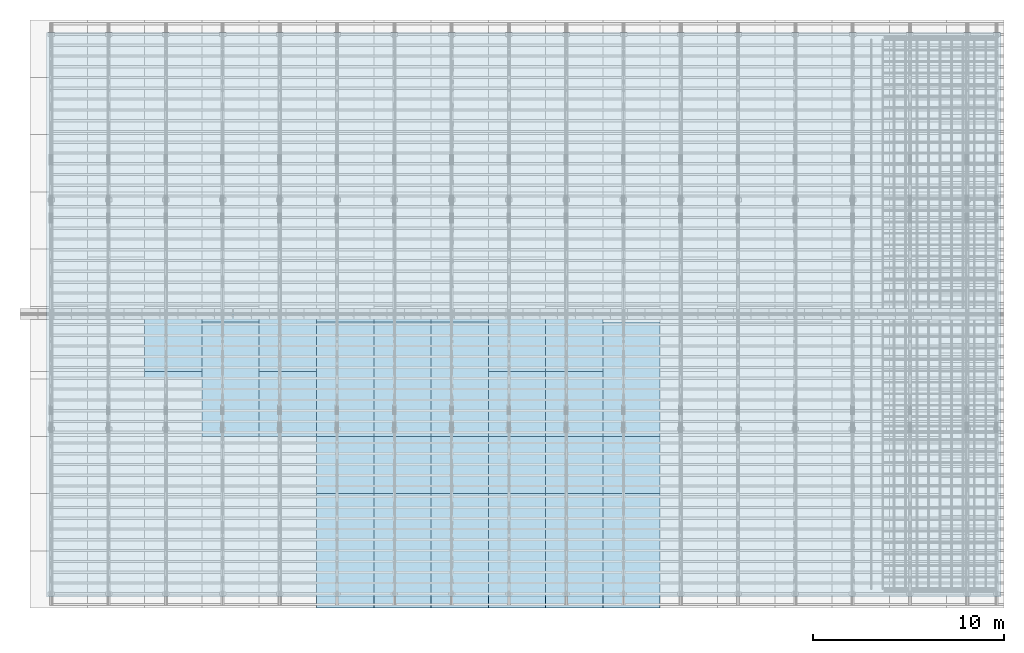
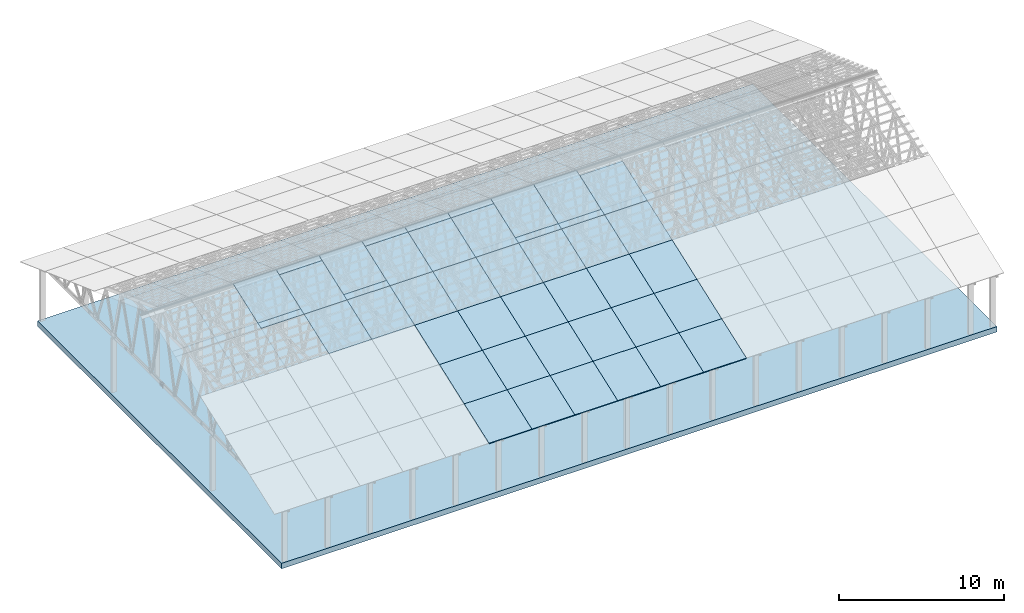
# One storey, part 6 of 189: 44 slabs, 43 elements without a shape of their own.
"""IFC2X3 building model written with IfcOpenShell, lengths in millimetres."""

from ifc_helpers import new_model, entity, si_unit, converted_unit, derived_unit, direction, frame, frame_2d, origin, place, context, subcontext, project, spatial, rectangle, extrude, material, layer, layer_set, type_object, element, aggregate, save


model = new_model("IFC2X3")

# Units and contexts
model_context = context("Model", 3, precision=0.01, world=origin(), true_north=direction((6.12303176911189e-17, 1.0)))
body_context = subcontext(model_context, "Body", "Model", "MODEL_VIEW")
ifc_project = project(units=[si_unit("LENGTHUNIT", "METRE", prefix="MILLI"), si_unit("AREAUNIT", "SQUARE_METRE"), si_unit("VOLUMEUNIT", "CUBIC_METRE"), converted_unit("PLANEANGLEUNIT", "DEGREE", entity("IfcRatioMeasure", 0.0174532925199433), si_unit("PLANEANGLEUNIT", "RADIAN"), dimensions=[0, 0, 0, 0, 0, 0, 0]), si_unit("MASSUNIT", "GRAM", prefix="KILO"), derived_unit("MASSDENSITYUNIT", [(si_unit("MASSUNIT", "GRAM", prefix="KILO"), 1), (si_unit("LENGTHUNIT", "METRE"), -3)]), si_unit("TIMEUNIT", "SECOND"), si_unit("FREQUENCYUNIT", "HERTZ"), si_unit("THERMODYNAMICTEMPERATUREUNIT", "DEGREE_CELSIUS"), derived_unit("THERMALTRANSMITTANCEUNIT", [(si_unit("MASSUNIT", "GRAM", prefix="KILO"), 1), (si_unit("THERMODYNAMICTEMPERATUREUNIT", "KELVIN"), -1), (si_unit("TIMEUNIT", "SECOND"), -3)]), derived_unit("VOLUMETRICFLOWRATEUNIT", [(si_unit("LENGTHUNIT", "METRE"), 3), (si_unit("TIMEUNIT", "SECOND"), -1)]), si_unit("ELECTRICCURRENTUNIT", "AMPERE"), si_unit("ELECTRICVOLTAGEUNIT", "VOLT"), si_unit("POWERUNIT", "WATT"), si_unit("FORCEUNIT", "NEWTON"), si_unit("ILLUMINANCEUNIT", "LUX"), si_unit("LUMINOUSFLUXUNIT", "LUMEN"), si_unit("LUMINOUSINTENSITYUNIT", "CANDELA"), derived_unit("USERDEFINED", [(si_unit("MASSUNIT", "GRAM", prefix="KILO"), -1), (si_unit("LENGTHUNIT", "METRE"), -2), (si_unit("TIMEUNIT", "SECOND"), 3), (si_unit("LUMINOUSFLUXUNIT", "LUMEN"), 1)]), derived_unit("LINEARVELOCITYUNIT", [(si_unit("LENGTHUNIT", "METRE"), 1), (si_unit("TIMEUNIT", "SECOND"), -1)]), si_unit("PRESSUREUNIT", "PASCAL"), derived_unit("USERDEFINED", [(si_unit("LENGTHUNIT", "METRE"), -2), (si_unit("MASSUNIT", "GRAM", prefix="KILO"), 1), (si_unit("TIMEUNIT", "SECOND"), -2)])], contexts=[model_context])

# Site, building, storey
site_placement = place(None, origin())
site = spatial("IfcSite", under=ifc_project, at=site_placement, CompositionType="ELEMENT")
building_placement = place(site_placement, origin())
building = spatial("IfcBuilding", under=site, at=building_placement, CompositionType="ELEMENT")
storey_placement = place(building_placement, origin())
storey = spatial("IfcBuildingStorey", under=building, at=storey_placement, Name="Default", CompositionType="ELEMENT", Elevation=0.0)

# Slab
ifc_material_1 = material(Name="IfcSurfaceStyle #136")
slab_type = type_object("IfcSlabType", Name="Floor 1", PredefinedType="FLOOR", material=ifc_material_1)
slab_1_placement = place(building_placement, origin())
element("IfcSlab", 1, at=slab_1_placement, inside=storey, type_object=slab_type, Name="Floor 1:Floor 1", ObjectType="Floor 1:Floor 1", PredefinedType="FLOOR", context=body_context, shape_type="SweptSolid", body=[
    extrude(rectangle(XDim=50000.0, YDim=29560.0, at=frame_2d((0.0, -2.72848410531878e-12), x_axis=(1.0, 0.0))), frame((25000.0, 14720.0, -4400.0), z_axis=(0.0, 0.0, 1.0), x_axis=(-1.0, 0.0, 0.0)), (0.0, 0.0, 1.0), 399.999999999997),
])

# Roof, slab
roof_1_placement = place(storey_placement, frame((29153.4200853156, -652.222549250773, 238.115215731819)))
roof_1 = element("IfcRoof", 2, at=roof_1_placement, inside=storey, ShapeType="NOTDEFINED")
ifc_material_2 = material()
ifc_layer = layer(ifc_material_2, 40.0)
ifc_layer_set = layer_set([ifc_layer])
slab_2_placement = place(roof_1_placement, origin())
slab_2 = element("IfcSlab", 3, at=slab_2_placement, material=ifc_layer_set, PredefinedType="ROOF", context=body_context, shape_type="SweptSolid", body=[
    extrude(rectangle(XDim=3192.53331742773, YDim=2999.99999999999, at=frame_2d((0.0, -3.41060513164848e-13), x_axis=(0.0, -1.0))), frame((1500.0, 1500.0, 545.955351399302), z_axis=(0.0, -0.342020143325668, 0.939692620785909), x_axis=(1.0, 0.0, 0.0)), (0.0, 0.342020143325668, 0.939692620785909), 42.5671108990364),
])
aggregate(roof_1, [slab_2])

roof_2_placement = place(storey_placement, frame((29153.4200853156, 2347.77745074922, 1330.02591853042)))
roof_2 = element("IfcRoof", 4, at=roof_2_placement, inside=storey, ShapeType="NOTDEFINED")
slab_3_placement = place(roof_2_placement, origin())
slab_3 = element("IfcSlab", 5, at=slab_3_placement, material=ifc_layer_set, PredefinedType="ROOF", context=body_context, shape_type="SweptSolid", body=[
    extrude(rectangle(XDim=3192.53331742773, YDim=2999.99999999999, at=frame_2d((0.0, -1.13686837721616e-13), x_axis=(0.0, -1.0))), frame((1500.0, 1500.0, 545.955351399302), z_axis=(0.0, -0.342020143325668, 0.939692620785909), x_axis=(1.0, 0.0, 0.0)), (0.0, 0.342020143325668, 0.939692620785909), 42.5671108990353),
])
aggregate(roof_2, [slab_3])

roof_3_placement = place(storey_placement, frame((29153.4200853156, 5347.77745074923, 2421.93662132902)))
roof_3 = element("IfcRoof", 6, at=roof_3_placement, inside=storey, ShapeType="NOTDEFINED")
slab_4_placement = place(roof_3_placement, origin())
slab_4 = element("IfcSlab", 7, at=slab_4_placement, material=ifc_layer_set, PredefinedType="ROOF", context=body_context, shape_type="SweptSolid", body=[
    extrude(rectangle(XDim=3192.53331742773, YDim=2999.99999999999, at=frame_2d((0.0, 0.0), x_axis=(0.0, -1.0))), frame((1500.0, 1500.0, 545.955351399302), z_axis=(0.0, -0.342020143325668, 0.939692620785909), x_axis=(1.0, 0.0, 0.0)), (0.0, 0.342020143325668, 0.939692620785909), 42.5671108990355),
])
aggregate(roof_3, [slab_4])

roof_4_placement = place(storey_placement, frame((29153.4200853156, 8347.77745074923, 3513.84732412761)))
roof_4 = element("IfcRoof", 8, at=roof_4_placement, inside=storey, ShapeType="NOTDEFINED")
slab_5_placement = place(roof_4_placement, origin())
slab_5 = element("IfcSlab", 9, at=slab_5_placement, material=ifc_layer_set, PredefinedType="ROOF", context=body_context, shape_type="SweptSolid", body=[
    extrude(rectangle(XDim=3192.53331742773, YDim=2999.99999999999, at=frame_2d((0.0, 0.0), x_axis=(0.0, -1.0))), frame((1500.0, 1500.0, 545.955351399301), z_axis=(0.0, -0.342020143325668, 0.939692620785909), x_axis=(1.0, 0.0, 0.0)), (0.0, 0.342020143325668, 0.939692620785909), 42.5671108990366),
])
aggregate(roof_4, [slab_5])

roof_5_placement = place(storey_placement, frame((29153.4200853156, 11347.7774507492, 4605.75802692621)))
roof_5 = element("IfcRoof", 10, at=roof_5_placement, inside=storey, ShapeType="NOTDEFINED")
slab_6_placement = place(roof_5_placement, origin())
slab_6 = element("IfcSlab", 11, at=slab_6_placement, material=ifc_layer_set, PredefinedType="ROOF", context=body_context, shape_type="SweptSolid", body=[
    extrude(rectangle(XDim=3192.53331742773, YDim=2999.99999999999, at=frame_2d((0.0, 0.0), x_axis=(0.0, -1.0))), frame((1500.0, 1500.0, 545.955351399303), z_axis=(0.0, -0.342020143325669, 0.939692620785908), x_axis=(1.0, 0.0, 0.0)), (0.0, 0.342020143325669, 0.939692620785908), 42.5671108990361),
])
aggregate(roof_5, [slab_6])

roof_6_placement = place(storey_placement, frame((26153.4200853156, -652.222549250765, 238.115215731819)))
roof_6 = element("IfcRoof", 12, at=roof_6_placement, inside=storey, ShapeType="NOTDEFINED")
slab_7_placement = place(roof_6_placement, origin())
slab_7 = element("IfcSlab", 13, at=slab_7_placement, material=ifc_layer_set, PredefinedType="ROOF", context=body_context, shape_type="SweptSolid", body=[
    extrude(rectangle(XDim=3192.53331742773, YDim=2999.99999999999, at=frame_2d((0.0, -3.41060513164848e-13), x_axis=(0.0, -1.0))), frame((1500.0, 1500.0, 545.955351399302), z_axis=(0.0, -0.342020143325668, 0.939692620785909), x_axis=(1.0, 0.0, 0.0)), (0.0, 0.342020143325668, 0.939692620785909), 42.5671108990364),
])
aggregate(roof_6, [slab_7])

roof_7_placement = place(storey_placement, frame((26153.4200853156, 2347.77745074923, 1330.02591853042)))
roof_7 = element("IfcRoof", 14, at=roof_7_placement, inside=storey, ShapeType="NOTDEFINED")
slab_8_placement = place(roof_7_placement, origin())
slab_8 = element("IfcSlab", 15, at=slab_8_placement, material=ifc_layer_set, PredefinedType="ROOF", context=body_context, shape_type="SweptSolid", body=[
    extrude(rectangle(XDim=3192.53331742773, YDim=2999.99999999999, at=frame_2d((0.0, -1.13686837721616e-13), x_axis=(0.0, -1.0))), frame((1500.0, 1500.0, 545.955351399302), z_axis=(0.0, -0.342020143325668, 0.939692620785909), x_axis=(1.0, 0.0, 0.0)), (0.0, 0.342020143325668, 0.939692620785909), 42.5671108990353),
])
aggregate(roof_7, [slab_8])

roof_8_placement = place(storey_placement, frame((26153.4200853156, 5347.77745074924, 2421.93662132902)))
roof_8 = element("IfcRoof", 16, at=roof_8_placement, inside=storey, ShapeType="NOTDEFINED")
slab_9_placement = place(roof_8_placement, origin())
slab_9 = element("IfcSlab", 17, at=slab_9_placement, material=ifc_layer_set, PredefinedType="ROOF", context=body_context, shape_type="SweptSolid", body=[
    extrude(rectangle(XDim=3192.53331742773, YDim=2999.99999999999, at=frame_2d((0.0, 0.0), x_axis=(0.0, -1.0))), frame((1500.0, 1500.0, 545.955351399302), z_axis=(0.0, -0.342020143325668, 0.939692620785909), x_axis=(1.0, 0.0, 0.0)), (0.0, 0.342020143325668, 0.939692620785909), 42.5671108990355),
])
aggregate(roof_8, [slab_9])

roof_9_placement = place(storey_placement, frame((26153.4200853156, 8347.77745074924, 3513.84732412761)))
roof_9 = element("IfcRoof", 18, at=roof_9_placement, inside=storey, ShapeType="NOTDEFINED")
slab_10_placement = place(roof_9_placement, origin())
slab_10 = element("IfcSlab", 19, at=slab_10_placement, material=ifc_layer_set, PredefinedType="ROOF", context=body_context, shape_type="SweptSolid", body=[
    extrude(rectangle(XDim=3192.53331742773, YDim=2999.99999999999, at=frame_2d((0.0, 0.0), x_axis=(0.0, -1.0))), frame((1500.0, 1500.0, 545.955351399301), z_axis=(0.0, -0.342020143325668, 0.939692620785909), x_axis=(1.0, 0.0, 0.0)), (0.0, 0.342020143325668, 0.939692620785909), 42.5671108990366),
])
aggregate(roof_9, [slab_10])

roof_10_placement = place(storey_placement, frame((26153.4200853156, 11347.7774507492, 4605.75802692621)))
roof_10 = element("IfcRoof", 20, at=roof_10_placement, inside=storey, ShapeType="NOTDEFINED")
slab_11_placement = place(roof_10_placement, origin())
slab_11 = element("IfcSlab", 21, at=slab_11_placement, material=ifc_layer_set, PredefinedType="ROOF", context=body_context, shape_type="SweptSolid", body=[
    extrude(rectangle(XDim=3192.53331742773, YDim=2999.99999999999, at=frame_2d((0.0, 0.0), x_axis=(0.0, -1.0))), frame((1500.0, 1500.0, 545.955351399303), z_axis=(0.0, -0.342020143325669, 0.939692620785908), x_axis=(1.0, 0.0, 0.0)), (0.0, 0.342020143325669, 0.939692620785908), 42.5671108990361),
])
aggregate(roof_10, [slab_11])

roof_11_placement = place(storey_placement, frame((26153.4200853156, 11750.0000438631, 4752.15507836903)))
roof_11 = element("IfcRoof", 22, at=roof_11_placement, inside=storey, ShapeType="NOTDEFINED")
slab_12_placement = place(roof_11_placement, origin())
slab_12 = element("IfcSlab", 23, at=slab_12_placement, material=ifc_layer_set, PredefinedType="ROOF", context=body_context, shape_type="SweptSolid", body=[
    extrude(rectangle(XDim=3192.53331742773, YDim=2999.99999999999, at=frame_2d((0.0, 0.0), x_axis=(0.0, -1.0))), frame((1500.0, 1500.0, 545.955351399303), z_axis=(0.0, -0.342020143325669, 0.939692620785908), x_axis=(1.0, 0.0, 0.0)), (0.0, 0.342020143325669, 0.939692620785908), 42.5671108990361),
])
aggregate(roof_11, [slab_12])

roof_12_placement = place(storey_placement, frame((23153.4200853156, -652.222549250756, 238.115215731819)))
roof_12 = element("IfcRoof", 24, at=roof_12_placement, inside=storey, ShapeType="NOTDEFINED")
slab_13_placement = place(roof_12_placement, origin())
slab_13 = element("IfcSlab", 25, at=slab_13_placement, material=ifc_layer_set, PredefinedType="ROOF", context=body_context, shape_type="SweptSolid", body=[
    extrude(rectangle(XDim=3192.53331742773, YDim=2999.99999999999, at=frame_2d((0.0, -3.41060513164848e-13), x_axis=(0.0, -1.0))), frame((1500.0, 1500.0, 545.955351399302), z_axis=(0.0, -0.342020143325668, 0.939692620785909), x_axis=(1.0, 0.0, 0.0)), (0.0, 0.342020143325668, 0.939692620785909), 42.5671108990364),
])
aggregate(roof_12, [slab_13])

roof_13_placement = place(storey_placement, frame((23153.4200853157, 2347.77745074924, 1330.02591853042)))
roof_13 = element("IfcRoof", 26, at=roof_13_placement, inside=storey, ShapeType="NOTDEFINED")
slab_14_placement = place(roof_13_placement, origin())
slab_14 = element("IfcSlab", 27, at=slab_14_placement, material=ifc_layer_set, PredefinedType="ROOF", context=body_context, shape_type="SweptSolid", body=[
    extrude(rectangle(XDim=3192.53331742773, YDim=2999.99999999999, at=frame_2d((0.0, -1.13686837721616e-13), x_axis=(0.0, -1.0))), frame((1500.0, 1500.0, 545.955351399302), z_axis=(0.0, -0.342020143325668, 0.939692620785909), x_axis=(1.0, 0.0, 0.0)), (0.0, 0.342020143325668, 0.939692620785909), 42.5671108990353),
])
aggregate(roof_13, [slab_14])

roof_14_placement = place(storey_placement, frame((23153.4200853157, 5347.77745074925, 2421.93662132902)))
roof_14 = element("IfcRoof", 28, at=roof_14_placement, inside=storey, ShapeType="NOTDEFINED")
slab_15_placement = place(roof_14_placement, origin())
slab_15 = element("IfcSlab", 29, at=slab_15_placement, material=ifc_layer_set, PredefinedType="ROOF", context=body_context, shape_type="SweptSolid", body=[
    extrude(rectangle(XDim=3192.53331742773, YDim=2999.99999999999, at=frame_2d((0.0, 0.0), x_axis=(0.0, -1.0))), frame((1500.0, 1500.0, 545.955351399302), z_axis=(0.0, -0.342020143325668, 0.939692620785909), x_axis=(1.0, 0.0, 0.0)), (0.0, 0.342020143325668, 0.939692620785909), 42.5671108990355),
])
aggregate(roof_14, [slab_15])

roof_15_placement = place(storey_placement, frame((23153.4200853157, 8347.77745074925, 3513.84732412761)))
roof_15 = element("IfcRoof", 30, at=roof_15_placement, inside=storey, ShapeType="NOTDEFINED")
slab_16_placement = place(roof_15_placement, origin())
slab_16 = element("IfcSlab", 31, at=slab_16_placement, material=ifc_layer_set, PredefinedType="ROOF", context=body_context, shape_type="SweptSolid", body=[
    extrude(rectangle(XDim=3192.53331742773, YDim=2999.99999999999, at=frame_2d((0.0, 0.0), x_axis=(0.0, -1.0))), frame((1500.0, 1500.0, 545.955351399301), z_axis=(0.0, -0.342020143325668, 0.939692620785909), x_axis=(1.0, 0.0, 0.0)), (0.0, 0.342020143325668, 0.939692620785909), 42.5671108990366),
])
aggregate(roof_15, [slab_16])

roof_16_placement = place(storey_placement, frame((23153.4200853157, 11347.7774507492, 4605.75802692621)))
roof_16 = element("IfcRoof", 32, at=roof_16_placement, inside=storey, ShapeType="NOTDEFINED")
slab_17_placement = place(roof_16_placement, origin())
slab_17 = element("IfcSlab", 33, at=slab_17_placement, material=ifc_layer_set, PredefinedType="ROOF", context=body_context, shape_type="SweptSolid", body=[
    extrude(rectangle(XDim=3192.53331742773, YDim=2999.99999999999, at=frame_2d((0.0, 0.0), x_axis=(0.0, -1.0))), frame((1500.0, 1500.0, 545.955351399303), z_axis=(0.0, -0.342020143325669, 0.939692620785908), x_axis=(1.0, 0.0, 0.0)), (0.0, 0.342020143325669, 0.939692620785908), 42.5671108990361),
])
aggregate(roof_16, [slab_17])

roof_17_placement = place(storey_placement, frame((23153.4200853157, 11750.0000438631, 4752.15507836903)))
roof_17 = element("IfcRoof", 34, at=roof_17_placement, inside=storey, ShapeType="NOTDEFINED")
slab_18_placement = place(roof_17_placement, origin())
slab_18 = element("IfcSlab", 35, at=slab_18_placement, material=ifc_layer_set, PredefinedType="ROOF", context=body_context, shape_type="SweptSolid", body=[
    extrude(rectangle(XDim=3192.53331742773, YDim=2999.99999999999, at=frame_2d((0.0, 0.0), x_axis=(0.0, -1.0))), frame((1500.0, 1500.0, 545.955351399303), z_axis=(0.0, -0.342020143325669, 0.939692620785908), x_axis=(1.0, 0.0, 0.0)), (0.0, 0.342020143325669, 0.939692620785908), 42.5671108990361),
])
aggregate(roof_17, [slab_18])

roof_18_placement = place(storey_placement, frame((20153.4200853156, -652.222549250747, 238.115215731819)))
roof_18 = element("IfcRoof", 36, at=roof_18_placement, inside=storey, ShapeType="NOTDEFINED")
slab_19_placement = place(roof_18_placement, origin())
slab_19 = element("IfcSlab", 37, at=slab_19_placement, material=ifc_layer_set, PredefinedType="ROOF", context=body_context, shape_type="SweptSolid", body=[
    extrude(rectangle(XDim=3192.53331742773, YDim=2999.99999999999, at=frame_2d((0.0, -3.41060513164848e-13), x_axis=(0.0, -1.0))), frame((1500.0, 1500.0, 545.955351399302), z_axis=(0.0, -0.342020143325668, 0.939692620785909), x_axis=(1.0, 0.0, 0.0)), (0.0, 0.342020143325668, 0.939692620785909), 42.5671108990364),
])
aggregate(roof_18, [slab_19])

roof_19_placement = place(storey_placement, frame((20153.4200853157, 2347.77745074925, 1330.02591853042)))
roof_19 = element("IfcRoof", 38, at=roof_19_placement, inside=storey, ShapeType="NOTDEFINED")
slab_20_placement = place(roof_19_placement, origin())
slab_20 = element("IfcSlab", 39, at=slab_20_placement, material=ifc_layer_set, PredefinedType="ROOF", context=body_context, shape_type="SweptSolid", body=[
    extrude(rectangle(XDim=3192.53331742773, YDim=2999.99999999999, at=frame_2d((0.0, -1.13686837721616e-13), x_axis=(0.0, -1.0))), frame((1500.0, 1500.0, 545.955351399302), z_axis=(0.0, -0.342020143325668, 0.939692620785909), x_axis=(1.0, 0.0, 0.0)), (0.0, 0.342020143325668, 0.939692620785909), 42.5671108990353),
])
aggregate(roof_19, [slab_20])

roof_20_placement = place(storey_placement, frame((20153.4200853157, 5347.77745074925, 2421.93662132902)))
roof_20 = element("IfcRoof", 40, at=roof_20_placement, inside=storey, ShapeType="NOTDEFINED")
slab_21_placement = place(roof_20_placement, origin())
slab_21 = element("IfcSlab", 41, at=slab_21_placement, material=ifc_layer_set, PredefinedType="ROOF", context=body_context, shape_type="SweptSolid", body=[
    extrude(rectangle(XDim=3192.53331742773, YDim=2999.99999999999, at=frame_2d((0.0, 0.0), x_axis=(0.0, -1.0))), frame((1500.0, 1500.0, 545.955351399302), z_axis=(0.0, -0.342020143325668, 0.939692620785909), x_axis=(1.0, 0.0, 0.0)), (0.0, 0.342020143325668, 0.939692620785909), 42.5671108990355),
])
aggregate(roof_20, [slab_21])

roof_21_placement = place(storey_placement, frame((20153.4200853157, 8347.77745074926, 3513.84732412761)))
roof_21 = element("IfcRoof", 42, at=roof_21_placement, inside=storey, ShapeType="NOTDEFINED")
slab_22_placement = place(roof_21_placement, origin())
slab_22 = element("IfcSlab", 43, at=slab_22_placement, material=ifc_layer_set, PredefinedType="ROOF", context=body_context, shape_type="SweptSolid", body=[
    extrude(rectangle(XDim=3192.53331742773, YDim=2999.99999999999, at=frame_2d((0.0, 0.0), x_axis=(0.0, -1.0))), frame((1500.0, 1500.0, 545.955351399301), z_axis=(0.0, -0.342020143325668, 0.939692620785909), x_axis=(1.0, 0.0, 0.0)), (0.0, 0.342020143325668, 0.939692620785909), 42.5671108990366),
])
aggregate(roof_21, [slab_22])

roof_22_placement = place(storey_placement, frame((20153.4200853157, 11347.7774507493, 4605.75802692621)))
roof_22 = element("IfcRoof", 44, at=roof_22_placement, inside=storey, ShapeType="NOTDEFINED")
slab_23_placement = place(roof_22_placement, origin())
slab_23 = element("IfcSlab", 45, at=slab_23_placement, material=ifc_layer_set, PredefinedType="ROOF", context=body_context, shape_type="SweptSolid", body=[
    extrude(rectangle(XDim=3192.53331742773, YDim=2999.99999999999, at=frame_2d((0.0, 0.0), x_axis=(0.0, -1.0))), frame((1500.0, 1500.0, 545.955351399303), z_axis=(0.0, -0.342020143325669, 0.939692620785908), x_axis=(1.0, 0.0, 0.0)), (0.0, 0.342020143325669, 0.939692620785908), 42.5671108990361),
])
aggregate(roof_22, [slab_23])

roof_23_placement = place(storey_placement, frame((20153.4200853157, 11750.0000438631, 4752.15507836903)))
roof_23 = element("IfcRoof", 46, at=roof_23_placement, inside=storey, ShapeType="NOTDEFINED")
slab_24_placement = place(roof_23_placement, origin())
slab_24 = element("IfcSlab", 47, at=slab_24_placement, material=ifc_layer_set, PredefinedType="ROOF", context=body_context, shape_type="SweptSolid", body=[
    extrude(rectangle(XDim=3192.53331742773, YDim=2999.99999999999, at=frame_2d((0.0, 0.0), x_axis=(0.0, -1.0))), frame((1500.0, 1500.0, 545.955351399303), z_axis=(0.0, -0.342020143325669, 0.939692620785908), x_axis=(1.0, 0.0, 0.0)), (0.0, 0.342020143325669, 0.939692620785908), 42.5671108990361),
])
aggregate(roof_23, [slab_24])

roof_24_placement = place(storey_placement, frame((17153.4200853157, -652.222549250739, 238.115215731819)))
roof_24 = element("IfcRoof", 48, at=roof_24_placement, inside=storey, ShapeType="NOTDEFINED")
slab_25_placement = place(roof_24_placement, origin())
slab_25 = element("IfcSlab", 49, at=slab_25_placement, material=ifc_layer_set, PredefinedType="ROOF", context=body_context, shape_type="SweptSolid", body=[
    extrude(rectangle(XDim=3192.53331742773, YDim=2999.99999999999, at=frame_2d((0.0, -3.41060513164848e-13), x_axis=(0.0, -1.0))), frame((1500.0, 1500.0, 545.955351399302), z_axis=(0.0, -0.342020143325668, 0.939692620785909), x_axis=(1.0, 0.0, 0.0)), (0.0, 0.342020143325668, 0.939692620785909), 42.5671108990364),
])
aggregate(roof_24, [slab_25])

roof_25_placement = place(storey_placement, frame((17153.4200853157, 2347.77745074926, 1330.02591853042)))
roof_25 = element("IfcRoof", 50, at=roof_25_placement, inside=storey, ShapeType="NOTDEFINED")
slab_26_placement = place(roof_25_placement, origin())
slab_26 = element("IfcSlab", 51, at=slab_26_placement, material=ifc_layer_set, PredefinedType="ROOF", context=body_context, shape_type="SweptSolid", body=[
    extrude(rectangle(XDim=3192.53331742773, YDim=2999.99999999999, at=frame_2d((0.0, -1.13686837721616e-13), x_axis=(0.0, -1.0))), frame((1500.0, 1500.0, 545.955351399302), z_axis=(0.0, -0.342020143325668, 0.939692620785909), x_axis=(1.0, 0.0, 0.0)), (0.0, 0.342020143325668, 0.939692620785909), 42.5671108990353),
])
aggregate(roof_25, [slab_26])

roof_26_placement = place(storey_placement, frame((17153.4200853157, 5347.77745074926, 2421.93662132902)))
roof_26 = element("IfcRoof", 52, at=roof_26_placement, inside=storey, ShapeType="NOTDEFINED")
slab_27_placement = place(roof_26_placement, origin())
slab_27 = element("IfcSlab", 53, at=slab_27_placement, material=ifc_layer_set, PredefinedType="ROOF", context=body_context, shape_type="SweptSolid", body=[
    extrude(rectangle(XDim=3192.53331742773, YDim=2999.99999999999, at=frame_2d((0.0, 0.0), x_axis=(0.0, -1.0))), frame((1500.0, 1500.0, 545.955351399302), z_axis=(0.0, -0.342020143325668, 0.939692620785909), x_axis=(1.0, 0.0, 0.0)), (0.0, 0.342020143325668, 0.939692620785909), 42.5671108990355),
])
aggregate(roof_26, [slab_27])

roof_27_placement = place(storey_placement, frame((17153.4200853157, 8347.77745074927, 3513.84732412761)))
roof_27 = element("IfcRoof", 54, at=roof_27_placement, inside=storey, ShapeType="NOTDEFINED")
slab_28_placement = place(roof_27_placement, origin())
slab_28 = element("IfcSlab", 55, at=slab_28_placement, material=ifc_layer_set, PredefinedType="ROOF", context=body_context, shape_type="SweptSolid", body=[
    extrude(rectangle(XDim=3192.53331742773, YDim=2999.99999999999, at=frame_2d((0.0, 0.0), x_axis=(0.0, -1.0))), frame((1500.0, 1500.0, 545.955351399301), z_axis=(0.0, -0.342020143325668, 0.939692620785909), x_axis=(1.0, 0.0, 0.0)), (0.0, 0.342020143325668, 0.939692620785909), 42.5671108990366),
])
aggregate(roof_27, [slab_28])

roof_28_placement = place(storey_placement, frame((17153.4200853157, 11347.7774507493, 4605.75802692621)))
roof_28 = element("IfcRoof", 56, at=roof_28_placement, inside=storey, ShapeType="NOTDEFINED")
slab_29_placement = place(roof_28_placement, origin())
slab_29 = element("IfcSlab", 57, at=slab_29_placement, material=ifc_layer_set, PredefinedType="ROOF", context=body_context, shape_type="SweptSolid", body=[
    extrude(rectangle(XDim=3192.53331742773, YDim=2999.99999999999, at=frame_2d((0.0, 0.0), x_axis=(0.0, -1.0))), frame((1500.0, 1500.0, 545.955351399303), z_axis=(0.0, -0.342020143325669, 0.939692620785908), x_axis=(1.0, 0.0, 0.0)), (0.0, 0.342020143325669, 0.939692620785908), 42.5671108990361),
])
aggregate(roof_28, [slab_29])

roof_29_placement = place(storey_placement, frame((17153.4200853157, 11750.0000438632, 4752.15507836903)))
roof_29 = element("IfcRoof", 58, at=roof_29_placement, inside=storey, ShapeType="NOTDEFINED")
slab_30_placement = place(roof_29_placement, origin())
slab_30 = element("IfcSlab", 59, at=slab_30_placement, material=ifc_layer_set, PredefinedType="ROOF", context=body_context, shape_type="SweptSolid", body=[
    extrude(rectangle(XDim=3192.53331742773, YDim=2999.99999999999, at=frame_2d((0.0, 0.0), x_axis=(0.0, -1.0))), frame((1500.0, 1500.0, 545.955351399303), z_axis=(0.0, -0.342020143325669, 0.939692620785908), x_axis=(1.0, 0.0, 0.0)), (0.0, 0.342020143325669, 0.939692620785908), 42.5671108990361),
])
aggregate(roof_29, [slab_30])

roof_30_placement = place(storey_placement, frame((14153.4200853157, -652.22254925073, 238.115215731819)))
roof_30 = element("IfcRoof", 60, at=roof_30_placement, inside=storey, ShapeType="NOTDEFINED")
slab_31_placement = place(roof_30_placement, origin())
slab_31 = element("IfcSlab", 61, at=slab_31_placement, material=ifc_layer_set, PredefinedType="ROOF", context=body_context, shape_type="SweptSolid", body=[
    extrude(rectangle(XDim=3192.53331742773, YDim=2999.99999999999, at=frame_2d((0.0, -3.41060513164848e-13), x_axis=(0.0, -1.0))), frame((1500.0, 1500.0, 545.955351399302), z_axis=(0.0, -0.342020143325668, 0.939692620785909), x_axis=(1.0, 0.0, 0.0)), (0.0, 0.342020143325668, 0.939692620785909), 42.5671108990364),
])
aggregate(roof_30, [slab_31])

roof_31_placement = place(storey_placement, frame((14153.4200853157, 2347.77745074927, 1330.02591853042)))
roof_31 = element("IfcRoof", 62, at=roof_31_placement, inside=storey, ShapeType="NOTDEFINED")
slab_32_placement = place(roof_31_placement, origin())
slab_32 = element("IfcSlab", 63, at=slab_32_placement, material=ifc_layer_set, PredefinedType="ROOF", context=body_context, shape_type="SweptSolid", body=[
    extrude(rectangle(XDim=3192.53331742773, YDim=2999.99999999999, at=frame_2d((0.0, -1.13686837721616e-13), x_axis=(0.0, -1.0))), frame((1500.0, 1500.0, 545.955351399302), z_axis=(0.0, -0.342020143325668, 0.939692620785909), x_axis=(1.0, 0.0, 0.0)), (0.0, 0.342020143325668, 0.939692620785909), 42.5671108990353),
])
aggregate(roof_31, [slab_32])

roof_32_placement = place(storey_placement, frame((14153.4200853157, 5347.77745074927, 2421.93662132902)))
roof_32 = element("IfcRoof", 64, at=roof_32_placement, inside=storey, ShapeType="NOTDEFINED")
slab_33_placement = place(roof_32_placement, origin())
slab_33 = element("IfcSlab", 65, at=slab_33_placement, material=ifc_layer_set, PredefinedType="ROOF", context=body_context, shape_type="SweptSolid", body=[
    extrude(rectangle(XDim=3192.53331742773, YDim=2999.99999999999, at=frame_2d((0.0, 0.0), x_axis=(0.0, -1.0))), frame((1500.0, 1500.0, 545.955351399302), z_axis=(0.0, -0.342020143325668, 0.939692620785909), x_axis=(1.0, 0.0, 0.0)), (0.0, 0.342020143325668, 0.939692620785909), 42.5671108990355),
])
aggregate(roof_32, [slab_33])

roof_33_placement = place(storey_placement, frame((14153.4200853157, 8347.77745074928, 3513.84732412761)))
roof_33 = element("IfcRoof", 66, at=roof_33_placement, inside=storey, ShapeType="NOTDEFINED")
slab_34_placement = place(roof_33_placement, origin())
slab_34 = element("IfcSlab", 67, at=slab_34_placement, material=ifc_layer_set, PredefinedType="ROOF", context=body_context, shape_type="SweptSolid", body=[
    extrude(rectangle(XDim=3192.53331742773, YDim=2999.99999999999, at=frame_2d((0.0, 0.0), x_axis=(0.0, -1.0))), frame((1500.0, 1500.0, 545.955351399301), z_axis=(0.0, -0.342020143325668, 0.939692620785909), x_axis=(1.0, 0.0, 0.0)), (0.0, 0.342020143325668, 0.939692620785909), 42.5671108990366),
])
aggregate(roof_33, [slab_34])

roof_34_placement = place(storey_placement, frame((14153.4200853157, 11347.7774507493, 4605.75802692621)))
roof_34 = element("IfcRoof", 68, at=roof_34_placement, inside=storey, ShapeType="NOTDEFINED")
slab_35_placement = place(roof_34_placement, origin())
slab_35 = element("IfcSlab", 69, at=slab_35_placement, material=ifc_layer_set, PredefinedType="ROOF", context=body_context, shape_type="SweptSolid", body=[
    extrude(rectangle(XDim=3192.53331742773, YDim=2999.99999999999, at=frame_2d((0.0, 0.0), x_axis=(0.0, -1.0))), frame((1500.0, 1500.0, 545.955351399303), z_axis=(0.0, -0.342020143325669, 0.939692620785908), x_axis=(1.0, 0.0, 0.0)), (0.0, 0.342020143325669, 0.939692620785908), 42.5671108990361),
])
aggregate(roof_34, [slab_35])

roof_35_placement = place(storey_placement, frame((14153.4200853157, 11750.0000438632, 4752.15507836903)))
roof_35 = element("IfcRoof", 70, at=roof_35_placement, inside=storey, ShapeType="NOTDEFINED")
slab_36_placement = place(roof_35_placement, origin())
slab_36 = element("IfcSlab", 71, at=slab_36_placement, material=ifc_layer_set, PredefinedType="ROOF", context=body_context, shape_type="SweptSolid", body=[
    extrude(rectangle(XDim=3192.53331742773, YDim=2999.99999999999, at=frame_2d((0.0, 0.0), x_axis=(0.0, -1.0))), frame((1500.0, 1500.0, 545.955351399303), z_axis=(0.0, -0.342020143325669, 0.939692620785908), x_axis=(1.0, 0.0, 0.0)), (0.0, 0.342020143325669, 0.939692620785908), 42.5671108990361),
])
aggregate(roof_35, [slab_36])

roof_36_placement = place(storey_placement, frame((11153.4200853157, 8347.77745074929, 3513.84732412761)))
roof_36 = element("IfcRoof", 72, at=roof_36_placement, inside=storey, ShapeType="NOTDEFINED")
slab_37_placement = place(roof_36_placement, origin())
slab_37 = element("IfcSlab", 73, at=slab_37_placement, material=ifc_layer_set, PredefinedType="ROOF", context=body_context, shape_type="SweptSolid", body=[
    extrude(rectangle(XDim=3192.53331742773, YDim=2999.99999999999, at=frame_2d((0.0, 0.0), x_axis=(0.0, -1.0))), frame((1500.0, 1500.0, 545.955351399301), z_axis=(0.0, -0.342020143325668, 0.939692620785909), x_axis=(1.0, 0.0, 0.0)), (0.0, 0.342020143325668, 0.939692620785909), 42.5671108990366),
])
aggregate(roof_36, [slab_37])

roof_37_placement = place(storey_placement, frame((11153.4200853157, 11347.7774507493, 4605.75802692621)))
roof_37 = element("IfcRoof", 74, at=roof_37_placement, inside=storey, ShapeType="NOTDEFINED")
slab_38_placement = place(roof_37_placement, origin())
slab_38 = element("IfcSlab", 75, at=slab_38_placement, material=ifc_layer_set, PredefinedType="ROOF", context=body_context, shape_type="SweptSolid", body=[
    extrude(rectangle(XDim=3192.53331742773, YDim=2999.99999999999, at=frame_2d((0.0, 0.0), x_axis=(0.0, -1.0))), frame((1500.0, 1500.0, 545.955351399303), z_axis=(0.0, -0.342020143325669, 0.939692620785908), x_axis=(1.0, 0.0, 0.0)), (0.0, 0.342020143325669, 0.939692620785908), 42.5671108990361),
])
aggregate(roof_37, [slab_38])

roof_38_placement = place(storey_placement, frame((11153.4200853157, 11750.0000438632, 4752.15507836903)))
roof_38 = element("IfcRoof", 76, at=roof_38_placement, inside=storey, ShapeType="NOTDEFINED")
slab_39_placement = place(roof_38_placement, origin())
slab_39 = element("IfcSlab", 77, at=slab_39_placement, material=ifc_layer_set, PredefinedType="ROOF", context=body_context, shape_type="SweptSolid", body=[
    extrude(rectangle(XDim=3192.53331742773, YDim=2999.99999999999, at=frame_2d((0.0, 0.0), x_axis=(0.0, -1.0))), frame((1500.0, 1500.0, 545.955351399303), z_axis=(0.0, -0.342020143325669, 0.939692620785908), x_axis=(1.0, 0.0, 0.0)), (0.0, 0.342020143325669, 0.939692620785908), 42.5671108990361),
])
aggregate(roof_38, [slab_39])

roof_39_placement = place(storey_placement, frame((8153.42008531577, 8347.77745074929, 3513.84732412761)))
roof_39 = element("IfcRoof", 78, at=roof_39_placement, inside=storey, ShapeType="NOTDEFINED")
slab_40_placement = place(roof_39_placement, origin())
slab_40 = element("IfcSlab", 79, at=slab_40_placement, material=ifc_layer_set, PredefinedType="ROOF", context=body_context, shape_type="SweptSolid", body=[
    extrude(rectangle(XDim=3192.53331742773, YDim=2999.99999999999, at=frame_2d((0.0, 0.0), x_axis=(0.0, -1.0))), frame((1500.0, 1500.0, 545.955351399301), z_axis=(0.0, -0.342020143325668, 0.939692620785909), x_axis=(1.0, 0.0, 0.0)), (0.0, 0.342020143325668, 0.939692620785909), 42.5671108990366),
])
aggregate(roof_39, [slab_40])

roof_40_placement = place(storey_placement, frame((8153.42008531577, 11347.7774507493, 4605.75802692621)))
roof_40 = element("IfcRoof", 80, at=roof_40_placement, inside=storey, ShapeType="NOTDEFINED")
slab_41_placement = place(roof_40_placement, origin())
slab_41 = element("IfcSlab", 81, at=slab_41_placement, material=ifc_layer_set, PredefinedType="ROOF", context=body_context, shape_type="SweptSolid", body=[
    extrude(rectangle(XDim=3192.53331742773, YDim=2999.99999999999, at=frame_2d((0.0, 0.0), x_axis=(0.0, -1.0))), frame((1500.0, 1500.0, 545.955351399303), z_axis=(0.0, -0.342020143325669, 0.939692620785908), x_axis=(1.0, 0.0, 0.0)), (0.0, 0.342020143325669, 0.939692620785908), 42.5671108990361),
])
aggregate(roof_40, [slab_41])

roof_41_placement = place(storey_placement, frame((8153.42008531577, 11750.0000438632, 4752.15507836903)))
roof_41 = element("IfcRoof", 82, at=roof_41_placement, inside=storey, ShapeType="NOTDEFINED")
slab_42_placement = place(roof_41_placement, origin())
slab_42 = element("IfcSlab", 83, at=slab_42_placement, material=ifc_layer_set, PredefinedType="ROOF", context=body_context, shape_type="SweptSolid", body=[
    extrude(rectangle(XDim=3192.53331742773, YDim=2999.99999999999, at=frame_2d((0.0, 0.0), x_axis=(0.0, -1.0))), frame((1500.0, 1500.0, 545.955351399303), z_axis=(0.0, -0.342020143325669, 0.939692620785908), x_axis=(1.0, 0.0, 0.0)), (0.0, 0.342020143325669, 0.939692620785908), 42.5671108990361),
])
aggregate(roof_41, [slab_42])

roof_42_placement = place(storey_placement, frame((5153.42008531579, 11347.7774507493, 4605.75802692621)))
roof_42 = element("IfcRoof", 84, at=roof_42_placement, inside=storey, ShapeType="NOTDEFINED")
slab_43_placement = place(roof_42_placement, origin())
slab_43 = element("IfcSlab", 85, at=slab_43_placement, material=ifc_layer_set, PredefinedType="ROOF", context=body_context, shape_type="SweptSolid", body=[
    extrude(rectangle(XDim=3192.53331742773, YDim=2999.99999999999, at=frame_2d((0.0, 0.0), x_axis=(0.0, -1.0))), frame((1500.0, 1500.0, 545.955351399303), z_axis=(0.0, -0.342020143325669, 0.939692620785908), x_axis=(1.0, 0.0, 0.0)), (0.0, 0.342020143325669, 0.939692620785908), 42.5671108990361),
])
aggregate(roof_42, [slab_43])

roof_43_placement = place(storey_placement, frame((5153.42008531579, 11750.0000438632, 4752.15507836903)))
roof_43 = element("IfcRoof", 86, at=roof_43_placement, inside=storey, ShapeType="NOTDEFINED")
slab_44_placement = place(roof_43_placement, origin())
slab_44 = element("IfcSlab", 87, at=slab_44_placement, material=ifc_layer_set, PredefinedType="ROOF", context=body_context, shape_type="SweptSolid", body=[
    extrude(rectangle(XDim=3192.53331742773, YDim=2999.99999999999, at=frame_2d((0.0, 0.0), x_axis=(0.0, -1.0))), frame((1500.0, 1500.0, 545.955351399303), z_axis=(0.0, -0.342020143325669, 0.939692620785908), x_axis=(1.0, 0.0, 0.0)), (0.0, 0.342020143325669, 0.939692620785908), 42.5671108990361),
])
aggregate(roof_43, [slab_44])

save(model, "model.ifc")
